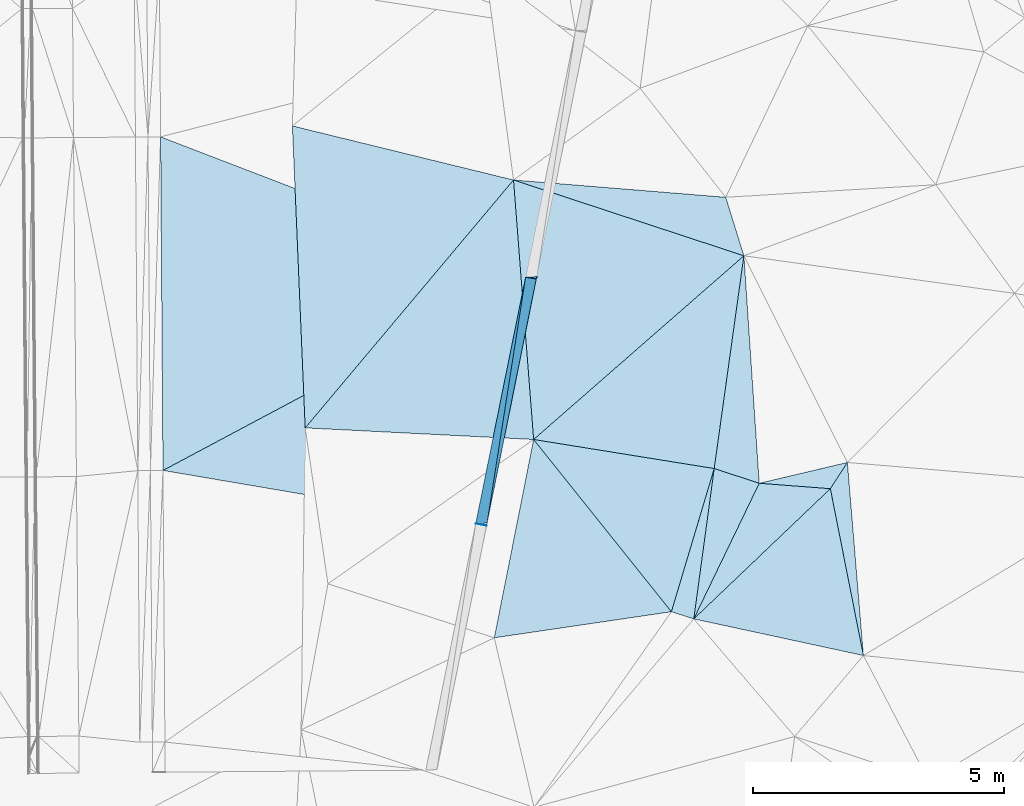
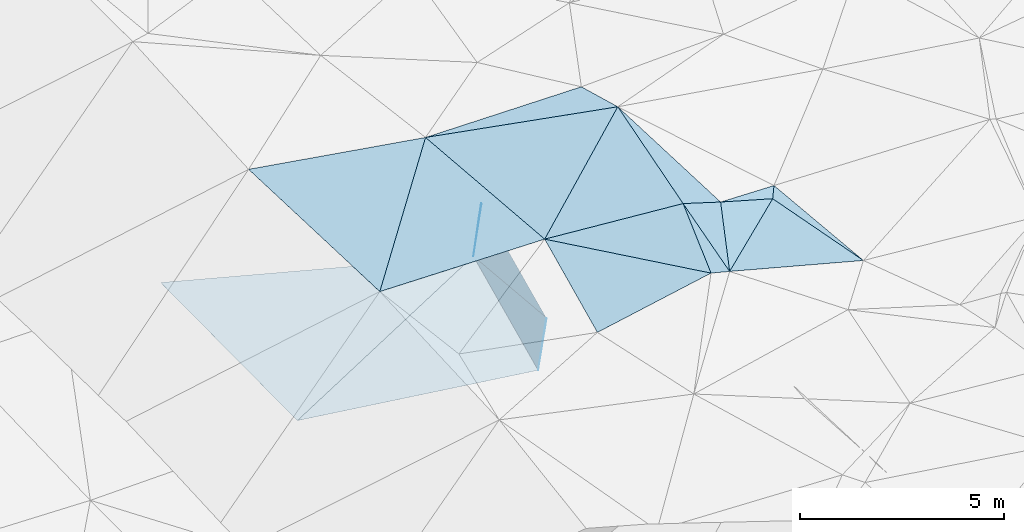
# One storey, part 41 of 275: 20 plates.
"""IFC2X3 building model written with IfcOpenShell, lengths in millimetres."""

from ifc_helpers import new_model, si_unit, frame, origin_with_axes, place, context, subcontext, project, spatial, polyline, outline, extrude, material, type_object, element, save


model = new_model("IFC2X3")

# Units and contexts
model_context = context("Model", 3, precision=1e-05, world=origin_with_axes())
body_context = subcontext(model_context, "Body", "Model", "MODEL_VIEW")
ifc_project = project(units=[si_unit("LENGTHUNIT", "METRE", prefix="MILLI"), si_unit("AREAUNIT", "SQUARE_METRE"), si_unit("VOLUMEUNIT", "CUBIC_METRE"), si_unit("MASSUNIT", "GRAM", prefix="KILO"), si_unit("TIMEUNIT", "SECOND"), si_unit("PLANEANGLEUNIT", "RADIAN"), si_unit("SOLIDANGLEUNIT", "STERADIAN"), si_unit("THERMODYNAMICTEMPERATUREUNIT", "DEGREE_CELSIUS"), si_unit("LUMINOUSINTENSITYUNIT", "LUMEN")], contexts=[model_context])

# Site, building, storey
site_placement = place(None, origin_with_axes())
site = spatial("IfcSite", under=ifc_project, at=site_placement, CompositionType="ELEMENT")
building_placement = place(site_placement, origin_with_axes())
building = spatial("IfcBuilding", under=site, at=building_placement, Name="Undefined", CompositionType="ELEMENT")
storey_placement = place(building_placement, origin_with_axes())
storey = spatial("IfcBuildingStorey", under=building, at=storey_placement, Name="Undefined", CompositionType="ELEMENT", Elevation=0.0)

# Plates
ifc_material = material()
plate_type_1 = type_object("IfcPlateType", PredefinedType="NOTDEFINED")
plate_1_placement = place(storey_placement, frame((-48426.8351468374, 28694.2218448821, 41907.4396825856), z_axis=(0.970409288359526, -0.193356275472872, -0.144634587152651), x_axis=(0.198309372945086, 0.97992483372389, 0.0205112859990302)))
element("IfcPlate", 1, at=plate_1_placement, inside=storey, type_object=plate_type_1, material=ifc_material, Name="00_PR", context=body_context, shape_type="SweptSolid", body=[
    extrude(outline(polyline([(0.0, 0.0), (5001.0517578125, -6.7157088778913e-09), (85.8123092651367, 1515.63586425781), (0.0, 0.0)])), frame((-8.85201319254618e-08, 2.18876761149539e-07, -0.5000001331573), z_axis=(0.0, 0.0, 1.0), x_axis=(1.0, 0.0, 0.0)), (0.0, 0.0, 1.0), 1.0),
])
plate_type_2 = type_object("IfcPlateType", PredefinedType="NOTDEFINED")
plate_2_placement = place(storey_placement, frame((-47435.0793920082, 33594.877047817, 42010.0193018111), z_axis=(0.971050550829368, -0.192530507250518, -0.141396009532941), x_axis=(0.139783937003715, -0.0220014620087739, 0.989937567034011)))
element("IfcPlate", 2, at=plate_2_placement, inside=storey, type_object=plate_type_2, material=ifc_material, Name="00_PR", context=body_context, shape_type="SweptSolid", body=[
    extrude(outline(polyline([(0.0, 0.0), (1515.77233886719, -2.83762346953154e-09), (1385.01220703125, 4953.63232421875), (0.0, 0.0)])), frame((-8.85201319254618e-08, 2.18876761149539e-07, -0.5000001331573), z_axis=(0.0, 0.0, 1.0), x_axis=(1.0, 0.0, 0.0)), (0.0, 0.0, 1.0), 1.0),
])
plate_type_3 = type_object("IfcPlateType", PredefinedType="NOTDEFINED")
plate_3_placement = place(storey_placement, frame((-47209.2722562084, 33605.2825043876, 43513.0959656925), z_axis=(0.945856655344127, -0.292807739159446, -0.140067181843412), x_axis=(-0.30276000702217, -0.951448508128292, -0.0555167950117993)))
element("IfcPlate", 3, at=plate_3_placement, inside=storey, type_object=plate_type_3, material=ifc_material, Name="00_PR", context=body_context, shape_type="SweptSolid", body=[
    extrude(outline(polyline([(0.0, 0.0), (46.0401229858398, -6.54836185276508e-11), (161.763107299805, 1511.34838867188), (0.0, 0.0)])), frame((-8.85201319254618e-08, 2.18876761149539e-07, -0.5000001331573), z_axis=(0.0, 0.0, 1.0), x_axis=(1.0, 0.0, 0.0)), (0.0, 0.0, 1.0), 1.0),
])
plate_type_4 = type_object("IfcPlateType", PredefinedType="NOTDEFINED")
plate_4_placement = place(storey_placement, frame((-48426.8457824076, 28694.46243452, 41907.4481731367), z_axis=(0.94913791827822, 0.287822607146076, -0.127653276111987), x_axis=(0.139813385041587, -0.0220064600114516, 0.98993329728875)))
element("IfcPlate", 4, at=plate_4_placement, inside=storey, type_object=plate_type_4, material=ifc_material, Name="00_PR", context=body_context, shape_type="SweptSolid", body=[
    extrude(outline(polyline([(0.0, 0.0), (1515.44653320313, 2.77941580861807e-09), (1515.89123535156, 10.5874872207642), (0.0, 0.0)])), frame((-8.85201319254618e-08, 2.18876761149539e-07, -0.5000001331573), z_axis=(0.0, 0.0, 1.0), x_axis=(1.0, 0.0, 0.0)), (0.0, 0.0, 1.0), 1.0),
])
plate_type_5 = type_object("IfcPlateType", PredefinedType="NOTDEFINED")
plate_5_placement = place(storey_placement, frame((-54693.007492606, 36384.1729363851, 42067.6551037013), z_axis=(-0.000144169717566869, 0.0204384007525999, -0.999791103676047), x_axis=(0.933411534985454, -0.358729891989295, -0.00746799500849117)))
element("IfcPlate", 5, at=plate_5_placement, inside=storey, type_object=plate_type_5, material=ifc_material, Name="00_PR", context=body_context, shape_type="SweptSolid", body=[
    extrude(outline(polyline([(0.0, 0.0), (7775.1796875, 5.62431523576379e-09), (2424.5966796875, 6174.7001953125), (0.0, 0.0)])), frame((-8.85201319254618e-08, 2.18876761149539e-07, -0.5000001331573), z_axis=(0.0, 0.0, 1.0), x_axis=(1.0, 0.0, 0.0)), (0.0, 0.0, 1.0), 1.0),
])
plate_type_6 = type_object("IfcPlateType", PredefinedType="NOTDEFINED")
plate_6_placement = place(storey_placement, frame((-47435.5651494518, 33594.9838179581, 42009.5901095134), z_axis=(-0.00045358140465047, 0.0210186550785641, -0.99977898077655), x_axis=(-0.198309372916258, -0.979924833729124, -0.0205112860276588)))
element("IfcPlate", 6, at=plate_6_placement, inside=storey, type_object=plate_type_6, material=ifc_material, Name="00_PR", context=body_context, shape_type="SweptSolid", body=[
    extrude(outline(polyline([(0.0, 0.0), (5001.0517578125, -6.7157088778913e-09), (5197.1435546875, 6304.39208984375), (0.0, 0.0)])), frame((-8.85201319254618e-08, 2.18876761149539e-07, -0.5000001331573), z_axis=(0.0, 0.0, 1.0), x_axis=(1.0, 0.0, 0.0)), (0.0, 0.0, 1.0), 1.0),
])
plate_type_7 = type_object("IfcPlateType", PredefinedType="NOTDEFINED")
plate_7_placement = place(storey_placement, frame((-43095.6337334408, 34019.5868933186, 44709.500719379), z_axis=(0.0483540966083631, 0.0239436833600895, -0.998543229594163), x_axis=(-0.138107858365577, -0.989949752073885, -0.0304254470226464)))
element("IfcPlate", 7, at=plate_7_placement, inside=storey, type_object=plate_type_7, material=ifc_material, Name="00", context=body_context, shape_type="SweptSolid", body=[
    extrude(outline(polyline([(0.0, 0.0), (4272.7392578125, 3.28873284161091e-09), (4201.56689453125, 3639.15307617188), (0.0, 0.0)])), frame((-8.85201319254618e-08, 2.18876761149539e-07, -0.5000001331573), z_axis=(0.0, 0.0, 1.0), x_axis=(1.0, 0.0, 0.0)), (0.0, 0.0, 1.0), 1.0),
])
plate_type_8 = type_object("IfcPlateType", PredefinedType="NOTDEFINED")
plate_8_placement = place(storey_placement, frame((-44091.7167777443, 26800.3938180885, 44499.5022806006), z_axis=(-0.0874852316271099, 0.0385178371449502, -0.995420871023321), x_axis=(0.134503040411684, 0.990558544463102, 0.0265085290265969)))
element("IfcPlate", 8, at=plate_8_placement, inside=storey, type_object=plate_type_8, material=ifc_material, Name="00", context=body_context, shape_type="SweptSolid", body=[
    extrude(outline(polyline([(0.0, 0.0), (3017.89672851563, -1.50612322613597e-09), (2845.49169921875, 930.202453613281), (0.0, 0.0)])), frame((-8.85201319254618e-08, 2.18876761149539e-07, -0.5000001331573), z_axis=(0.0, 0.0, 1.0), x_axis=(1.0, 0.0, 0.0)), (0.0, 0.0, 1.0), 1.0),
])
plate_type_9 = type_object("IfcPlateType", PredefinedType="NOTDEFINED")
plate_9_placement = place(storey_placement, frame((-43685.7741749204, 29789.7935700972, 44579.5005417997), z_axis=(-0.0348190301773896, 0.0314596160976656, -0.998898357037639), x_axis=(-0.134503040408605, -0.990558544463092, -0.0265085290425958)))
element("IfcPlate", 9, at=plate_9_placement, inside=storey, type_object=plate_type_9, material=ifc_material, Name="00", context=body_context, shape_type="SweptSolid", body=[
    extrude(outline(polyline([(0.0, 0.0), (3017.89672851563, -1.50612322613597e-09), (2936.61474609375, 460.861450195313), (0.0, 0.0)])), frame((-8.85201319254618e-08, 2.18876761149539e-07, -0.5000001331573), z_axis=(0.0, 0.0, 1.0), x_axis=(1.0, 0.0, 0.0)), (0.0, 0.0, 1.0), 1.0),
])
plate_type_10 = type_object("IfcPlateType", PredefinedType="NOTDEFINED")
plate_10_placement = place(storey_placement, frame((-42790.8383577534, 29496.6371529445, 44489.5023053664), z_axis=(-0.0861399708145049, 0.0426094644551713, -0.995371457781928), x_axis=(-0.946003676683447, 0.309881855552747, 0.0951329559121732)))
element("IfcPlate", 10, at=plate_10_placement, inside=storey, type_object=plate_type_10, material=ifc_material, Name="00", context=body_context, shape_type="SweptSolid", body=[
    extrude(outline(polyline([(0.0, 0.0), (946.044372558594, 8.78571881912649e-10), (1710.91333007813, 4203.7216796875), (0.0, 0.0)])), frame((-8.85201319254618e-08, 2.18876761149539e-07, -0.5000001331573), z_axis=(0.0, 0.0, 1.0), x_axis=(1.0, 0.0, 0.0)), (0.0, 0.0, 1.0), 1.0),
])
plate_type_11 = type_object("IfcPlateType", PredefinedType="NOTDEFINED")
plate_11_placement = place(storey_placement, frame((-40719.1589433001, 26071.8397658614, 44089.5032960662), z_axis=(-0.114766678147145, -0.00178589184110273, -0.993390869787619), x_axis=(-0.19437997661615, 0.980708007813722, 0.0206936729640887)))
element("IfcPlate", 11, at=plate_11_placement, inside=storey, type_object=plate_type_11, material=ifc_material, Name="00", context=body_context, shape_type="SweptSolid", body=[
    extrude(outline(polyline([(0.0, 0.0), (3382.67651367188, -2.9831426218152e-09), (3827.29467773438, 435.791839599609), (0.0, 0.0)])), frame((-8.85201319254618e-08, 2.18876761149539e-07, -0.5000001331573), z_axis=(0.0, 0.0, 1.0), x_axis=(1.0, 0.0, 0.0)), (0.0, 0.0, 1.0), 1.0),
])
plate_type_12 = type_object("IfcPlateType", PredefinedType="NOTDEFINED")
plate_12_placement = place(storey_placement, frame((-41038.6180883152, 29910.5182433646, 44119.5136647487), z_axis=(-0.221718855832373, 0.0691854820994227, -0.972653133462826), x_axis=(-0.543097199385713, -0.837208137206607, 0.0642492569174003)))
element("IfcPlate", 12, at=plate_12_placement, inside=storey, type_object=plate_type_12, material=ifc_material, Name="00", context=body_context, shape_type="SweptSolid", body=[
    extrude(outline(polyline([(0.0, 0.0), (622.575317382813, -2.11002770811319e-10), (1321.92846679688, 1277.18640136719), (0.0, 0.0)])), frame((-8.85201319254618e-08, 2.18876761149539e-07, -0.5000001331573), z_axis=(0.0, 0.0, 1.0), x_axis=(1.0, 0.0, 0.0)), (0.0, 0.0, 1.0), 1.0),
])
plate_type_13 = type_object("IfcPlateType", PredefinedType="NOTDEFINED")
plate_13_placement = place(storey_placement, frame((-43095.6268777212, 34019.5931309039, 44709.5012875087), z_axis=(0.0620643576394419, 0.0364197453888115, -0.997407448165802), x_axis=(-0.948850268352023, 0.312110551455711, -0.0476463211413696)))
element("IfcPlate", 13, at=plate_13_placement, inside=storey, type_object=plate_type_13, material=ifc_material, Name="00", context=body_context, shape_type="SweptSolid", body=[
    extrude(outline(polyline([(0.0, 0.0), (4827.2353515625, -1.57051545102149e-08), (704.854797363281, 993.619506835938), (0.0, 0.0)])), frame((-8.85201319254618e-08, 2.18876761149539e-07, -0.5000001331573), z_axis=(0.0, 0.0, 1.0), x_axis=(1.0, 0.0, 0.0)), (0.0, 0.0, 1.0), 1.0),
])
plate_type_14 = type_object("IfcPlateType", PredefinedType="NOTDEFINED")
plate_14_placement = place(storey_placement, frame((-41376.6867994839, 29389.256993444, 44159.5036885927), z_axis=(-0.121340921545643, -0.00310549198790329, -0.992606032964724), x_axis=(0.194379976620059, -0.980708007812862, -0.0206936729681282)))
element("IfcPlate", 14, at=plate_14_placement, inside=storey, type_object=plate_type_14, material=ifc_material, Name="00", context=body_context, shape_type="SweptSolid", body=[
    extrude(outline(polyline([(0.0, 0.0), (3382.67651367188, -2.9831426218152e-09), (2004.15270996094, 3189.47827148438), (0.0, 0.0)])), frame((-8.85201319254618e-08, 2.18876761149539e-07, -0.5000001331573), z_axis=(0.0, 0.0, 1.0), x_axis=(1.0, 0.0, 0.0)), (0.0, 0.0, 1.0), 1.0),
])
plate_type_15 = type_object("IfcPlateType", PredefinedType="NOTDEFINED")
plate_15_placement = place(storey_placement, frame((-47275.8778457355, 30367.4623312111, 44419.5010630496), z_axis=(0.0621525829733873, 0.0205650068723621, -0.99785476744969), x_axis=(0.624354930459668, -0.780808058552349, 0.022796853081388)))
element("IfcPlate", 15, at=plate_15_placement, inside=storey, type_object=plate_type_15, material=ifc_material, Name="00", context=body_context, shape_type="SweptSolid", body=[
    extrude(outline(polyline([(0.0, 0.0), (4386.5703125, 1.22236087918282e-09), (2587.30590820313, 3079.439453125), (0.0, 0.0)])), frame((-8.85201319254618e-08, 2.18876761149539e-07, -0.5000001331573), z_axis=(0.0, 0.0, 1.0), x_axis=(1.0, 0.0, 0.0)), (0.0, 0.0, 1.0), 1.0),
])
plate_type_16 = type_object("IfcPlateType", PredefinedType="NOTDEFINED")
plate_16_placement = place(storey_placement, frame((-47675.9536752535, 35526.2139248073, 44479.5008207706), z_axis=(0.0553631150139786, 0.0159049326952608, -0.998339600843274), x_axis=(0.948850268355997, -0.312110551444562, 0.0476463211352651)))
element("IfcPlate", 16, at=plate_16_placement, inside=storey, type_object=plate_type_16, material=ifc_material, Name="00", context=body_context, shape_type="SweptSolid", body=[
    extrude(outline(polyline([(0.0, 0.0), (4827.2353515625, -1.57051545102149e-08), (1986.8515625, 4777.95166015625), (0.0, 0.0)])), frame((-8.85201319254618e-08, 2.18876761149539e-07, -0.5000001331573), z_axis=(0.0, 0.0, 1.0), x_axis=(1.0, 0.0, 0.0)), (0.0, 0.0, 1.0), 1.0),
])
plate_type_17 = type_object("IfcPlateType", PredefinedType="NOTDEFINED")
plate_17_placement = place(storey_placement, frame((-44091.7823946378, 26800.4255221616, 44499.5147660199), z_axis=(-0.218719030316808, 0.101927903821756, -0.970449735019686), x_axis=(0.434541833198856, 0.900645455827219, -0.00334037392489741)))
element("IfcPlate", 17, at=plate_17_placement, inside=storey, type_object=plate_type_17, material=ifc_material, Name="00", context=body_context, shape_type="SweptSolid", body=[
    extrude(outline(polyline([(0.0, 0.0), (2993.6767578125, -2.58296495303512e-09), (3512.60375976563, 1360.52001953125), (0.0, 0.0)])), frame((-8.85201319254618e-08, 2.18876761149539e-07, -0.5000001331573), z_axis=(0.0, 0.0, 1.0), x_axis=(1.0, 0.0, 0.0)), (0.0, 0.0, 1.0), 1.0),
])
plate_type_18 = type_object("IfcPlateType", PredefinedType="NOTDEFINED")
plate_18_placement = place(storey_placement, frame((-51817.8098005125, 30597.6233957956, 44298.5001892088), z_axis=(0.020273513422285, 0.0196725834296721, -0.999600907419916), x_axis=(-0.0423166276448251, 0.998927335941149, 0.01880107800867)))
element("IfcPlate", 18, at=plate_18_placement, inside=storey, type_object=plate_type_18, material=ifc_material, Name="00", context=body_context, shape_type="SweptSolid", body=[
    extrude(outline(polyline([(0.0, 0.0), (6010.29345703125, -4.14729584008455e-09), (4751.43994140625, 4347.6923828125), (0.0, 0.0)])), frame((-8.85201319254618e-08, 2.18876761149539e-07, -0.5000001331573), z_axis=(0.0, 0.0, 1.0), x_axis=(1.0, 0.0, 0.0)), (0.0, 0.0, 1.0), 1.0),
])
plate_type_19 = type_object("IfcPlateType", PredefinedType="NOTDEFINED")
plate_19_placement = place(storey_placement, frame((-47675.9676936395, 35526.2128434638, 44479.5002241989), z_axis=(0.0273247999598717, 0.0137443710919351, -0.999532114326719), x_axis=(0.0773147816451565, -0.996939304961681, -0.0115951180107314)))
element("IfcPlate", 19, at=plate_19_placement, inside=storey, type_object=plate_type_19, material=ifc_material, Name="00", context=body_context, shape_type="SweptSolid", body=[
    extrude(outline(polyline([(0.0, 0.0), (5174.591796875, -4.38012648373842e-09), (4595.380859375, 4512.326171875), (0.0, 0.0)])), frame((-8.85201319254618e-08, 2.18876761149539e-07, -0.5000001331573), z_axis=(0.0, 0.0, 1.0), x_axis=(1.0, 0.0, 0.0)), (0.0, 0.0, 1.0), 1.0),
])
plate_type_20 = type_object("IfcPlateType", PredefinedType="NOTDEFINED")
plate_20_placement = place(storey_placement, frame((-44537.1092015345, 26942.3862097259, 44519.5005266144), z_axis=(0.0457065242514452, 0.00738297633802937, -0.998927627659404), x_axis=(-0.624354930459024, 0.780808058553361, -0.0227968530643715)))
element("IfcPlate", 20, at=plate_20_placement, inside=storey, type_object=plate_type_20, material=ifc_material, Name="00", context=body_context, shape_type="SweptSolid", body=[
    extrude(outline(polyline([(0.0, 0.0), (4386.5703125, 1.22236087918282e-09), (1690.34106445313, 2445.16821289063), (0.0, 0.0)])), frame((-8.85201319254618e-08, 2.18876761149539e-07, -0.5000001331573), z_axis=(0.0, 0.0, 1.0), x_axis=(1.0, 0.0, 0.0)), (0.0, 0.0, 1.0), 1.0),
])

save(model, "model.ifc")
